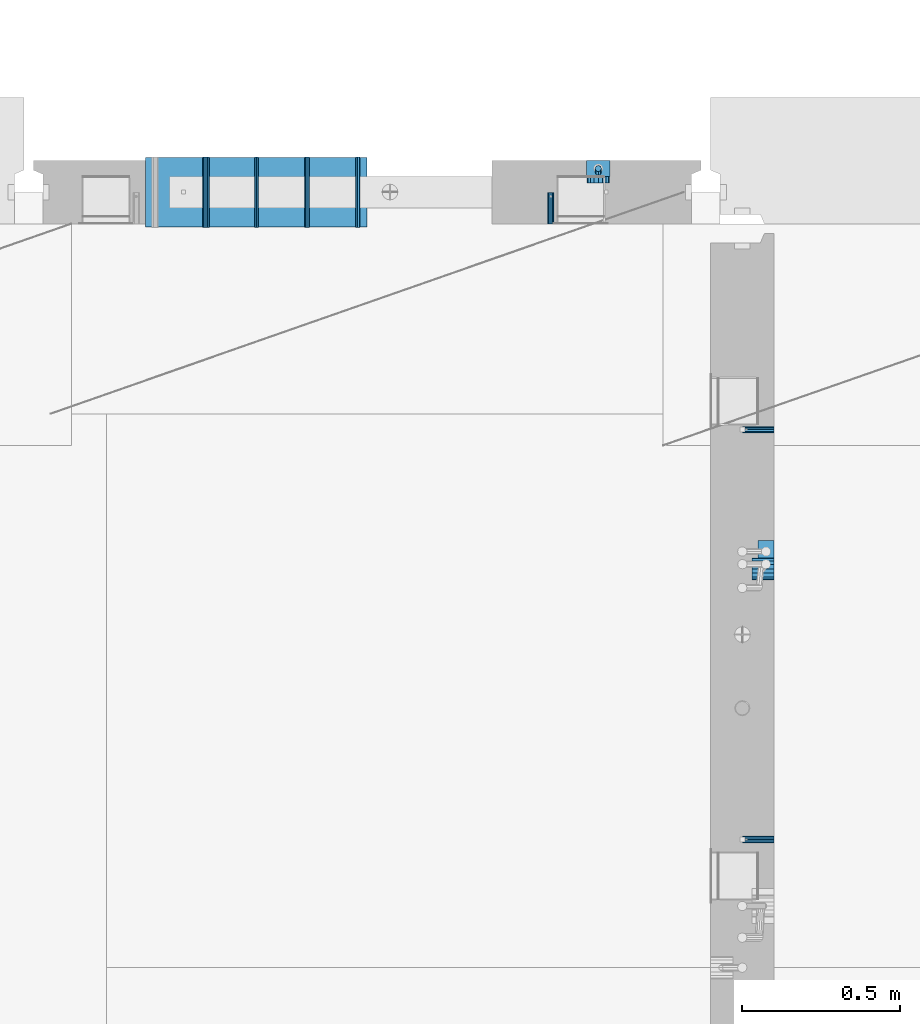
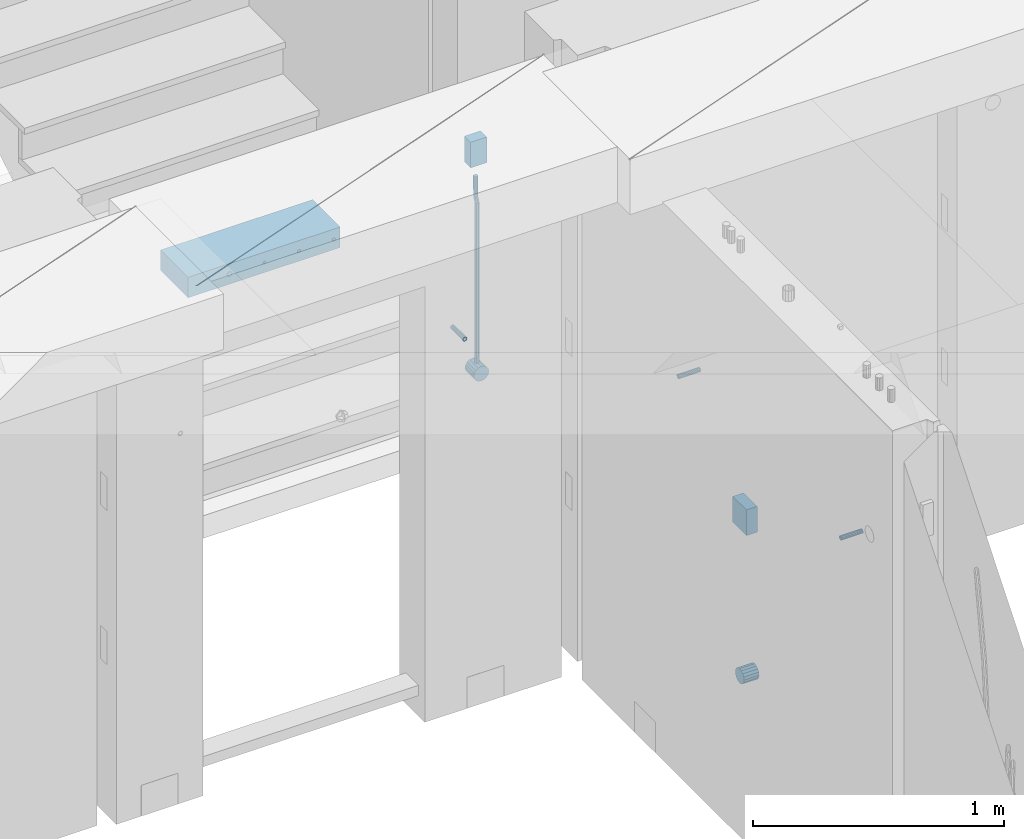
# One storey, part 144 of 341: 13 beams, 5 elements without a shape of their own.
"""IFC2X3 building model written with IfcOpenShell, lengths in millimetres."""

from ifc_helpers import new_model, si_unit, frame, origin_with_axes, place, context, subcontext, project, spatial, faceted_brep, material, type_object, element, aggregate, save


model = new_model("IFC2X3")

# Units and contexts
model_context = context("Model", 3, precision=1e-05, world=origin_with_axes())
body_context = subcontext(model_context, "Body", "Model", "MODEL_VIEW")
ifc_project = project(units=[si_unit("LENGTHUNIT", "METRE", prefix="MILLI"), si_unit("AREAUNIT", "SQUARE_METRE"), si_unit("VOLUMEUNIT", "CUBIC_METRE"), si_unit("MASSUNIT", "GRAM", prefix="KILO"), si_unit("TIMEUNIT", "SECOND"), si_unit("PLANEANGLEUNIT", "RADIAN"), si_unit("SOLIDANGLEUNIT", "STERADIAN"), si_unit("THERMODYNAMICTEMPERATUREUNIT", "DEGREE_CELSIUS"), si_unit("LUMINOUSINTENSITYUNIT", "LUMEN")], contexts=[model_context])

# Site, building, storey
site_placement = place(None, origin_with_axes())
site = spatial("IfcSite", under=ifc_project, at=site_placement, CompositionType="ELEMENT")
building_placement = place(site_placement, origin_with_axes())
building = spatial("IfcBuilding", under=site, at=building_placement, CompositionType="ELEMENT")
storey_placement = place(building_placement, origin_with_axes())
storey = spatial("IfcBuildingStorey", under=building, at=storey_placement, Name="5", CompositionType="ELEMENT", Elevation=0.0)

# Assemblies, beams
assembly_1_placement = place(storey_placement, origin_with_axes())
assembly_1 = element("IfcElementAssembly", 1, at=assembly_1_placement, inside=storey, AssemblyPlace="NOTDEFINED", PredefinedType="REINFORCEMENT_UNIT")
assembly_2_placement = place(assembly_1_placement, origin_with_axes())
assembly_2 = element("IfcElementAssembly", 2, at=assembly_2_placement, Name="Steel Assembly", AssemblyPlace="NOTDEFINED", PredefinedType="RIGID_FRAME")
ifc_material_1 = material(Name="STEEL/Steel_Undefined")
beam_type_1 = type_object("IfcBeamType", PredefinedType="NOTDEFINED")
beam_1_placement = place(assembly_2_placement, frame((21910.0, 13134.9999119588, 95555.0), z_axis=(0.0, -1.0, 0.0), x_axis=(-1.0, 3.00000001838171e-08, 0.0)))
beam_1 = element("IfcBeam", 3, at=beam_1_placement, type_object=beam_type_1, material=ifc_material_1, Name="M16", context=body_context, shape_type="Brep", body=[
    faceted_brep([(0.0, -8.49999999999272, -1.45519152283669e-11), (0.0, -7.36121593215648, 4.24999999998545), (100.000000000262, -7.36121593215648, 4.24999999998545), (100.000000000262, -8.49999999999272, -1.45519152283669e-11), (0.0, -4.24999999998545, 7.36121593216376), (100.000000000262, -4.24999999998545, 7.36121593216376), (0.0, 1.45519152283669e-11, 8.49999999998545), (100.000000000262, 1.45519152283669e-11, 8.49999999998545), (0.0, 4.25000000001455, 7.36121593216376), (100.000000000262, 4.25000000001455, 7.36121593216376), (0.0, 7.36121593217104, 4.24999999998545), (100.000000000262, 7.36121593217104, 4.24999999998545), (0.0, 8.50000000000728, 0.0), (100.000000000262, 8.50000000000728, 0.0), (0.0, 7.36121593217104, -4.25000000001455), (100.000000000262, 7.36121593217104, -4.25000000001455), (0.0, 4.25000000000728, -7.36121593219286), (100.000000000262, 4.25000000000728, -7.36121593219286), (0.0, 7.27595761418343e-12, -8.5), (100.000000000262, 7.27595761418343e-12, -8.5), (0.0, -4.24999999999272, -7.36121593217831), (100.000000000262, -4.24999999999272, -7.36121593217831), (0.0, -7.36121593215648, -4.25), (100.000000000262, -7.36121593215648, -4.25), (0.0, -10.4999999999927, -1.45519152283669e-11), (0.0, -9.09326673972828, -5.25000000001455), (100.000000000262, -9.09326673972828, -5.25000000001455), (100.000000000262, -10.4999999999927, -1.45519152283669e-11), (0.0, -5.24999999998545, -9.09326673974283), (100.000000000262, -5.24999999998545, -9.09326673974283), (0.0, 7.27595761418343e-12, -10.5), (100.000000000262, 7.27595761418343e-12, -10.5), (0.0, 5.25000000001455, -9.09326673975738), (100.000000000262, 5.25000000001455, -9.09326673975738), (0.0, 9.09326673975011, -5.25000000001455), (100.000000000262, 9.09326673975011, -5.25000000001455), (0.0, 10.5000000000073, -1.45519152283669e-11), (100.000000000262, 10.5000000000073, -1.45519152283669e-11), (0.0, 9.09326673975011, 5.25), (100.000000000262, 9.09326673975011, 5.25), (0.0, 5.25000000000728, 9.09326673972828), (100.000000000262, 5.25000000000728, 9.09326673972828), (0.0, 1.45519152283669e-11, 10.4999999999854), (100.000000000262, 1.45519152283669e-11, 10.4999999999854), (0.0, -5.24999999999272, 9.09326673972828), (100.000000000262, -5.24999999999272, 9.09326673972828), (0.0, -9.09326673972828, 5.24999999998545), (100.000000000262, -9.09326673972828, 5.24999999998545)], [[[0, 1, 2, 3]], [[1, 4, 5, 2]], [[4, 6, 7, 5]], [[6, 8, 9, 7]], [[8, 10, 11, 9]], [[10, 12, 13, 11]], [[12, 14, 15, 13]], [[14, 16, 17, 15]], [[16, 18, 19, 17]], [[18, 20, 21, 19]], [[20, 22, 23, 21]], [[22, 0, 3, 23]], [[24, 25, 26, 27]], [[25, 28, 29, 26]], [[28, 30, 31, 29]], [[30, 32, 33, 31]], [[32, 34, 35, 33]], [[34, 36, 37, 35]], [[36, 38, 39, 37]], [[38, 40, 41, 39]], [[40, 42, 43, 41]], [[42, 44, 45, 43]], [[44, 46, 47, 45]], [[46, 24, 27, 47]], [[29, 31, 33, 35, 37, 39, 41, 43, 45, 47, 27, 26], [5, 7, 9, 11, 13, 15, 17, 19, 21, 23, 3, 2]], [[46, 44, 42, 40, 38, 36, 34, 32, 30, 28, 25, 24], [22, 20, 18, 16, 14, 12, 10, 8, 6, 4, 1, 0]]]),
])
aggregate(assembly_2, [beam_1])
assembly_3_placement = place(assembly_1_placement, origin_with_axes())
assembly_3 = element("IfcElementAssembly", 4, at=assembly_3_placement, Name="Steel Assembly", AssemblyPlace="NOTDEFINED", PredefinedType="RIGID_FRAME")
beam_2_placement = place(assembly_3_placement, frame((21910.0, 14429.9999119589, 95555.0), z_axis=(0.0, 1.0, 0.0), x_axis=(-1.0, 3.00000001838171e-08, 0.0)))
beam_2 = element("IfcBeam", 5, at=beam_2_placement, type_object=beam_type_1, material=ifc_material_1, Name="M16", context=body_context, shape_type="Brep", body=[
    faceted_brep([(0.0, -8.49999999999272, -1.45519152283669e-11), (0.0, -7.36121593215648, 4.24999999998545), (100.000000000262, -7.36121593215648, 4.24999999998545), (100.000000000262, -8.49999999999272, -1.45519152283669e-11), (0.0, -4.24999999998545, 7.36121593216376), (100.000000000262, -4.24999999998545, 7.36121593216376), (0.0, 1.45519152283669e-11, 8.49999999998545), (100.000000000262, 1.45519152283669e-11, 8.49999999998545), (0.0, 4.25000000001455, 7.36121593216376), (100.000000000262, 4.25000000001455, 7.36121593216376), (0.0, 7.36121593217104, 4.24999999998545), (100.000000000262, 7.36121593217104, 4.24999999998545), (0.0, 8.50000000000728, 0.0), (100.000000000262, 8.50000000000728, 0.0), (0.0, 7.36121593217104, -4.25000000001455), (100.000000000262, 7.36121593217104, -4.25000000001455), (0.0, 4.25000000000728, -7.36121593219286), (100.000000000262, 4.25000000000728, -7.36121593219286), (0.0, 7.27595761418343e-12, -8.5), (100.000000000262, 7.27595761418343e-12, -8.5), (0.0, -4.24999999999272, -7.36121593217831), (100.000000000262, -4.24999999999272, -7.36121593217831), (0.0, -7.36121593215648, -4.25), (100.000000000262, -7.36121593215648, -4.25), (0.0, -10.4999999999927, -1.45519152283669e-11), (0.0, -9.09326673972828, -5.25000000001455), (100.000000000262, -9.09326673972828, -5.25000000001455), (100.000000000262, -10.4999999999927, -1.45519152283669e-11), (0.0, -5.24999999998545, -9.09326673974283), (100.000000000262, -5.24999999998545, -9.09326673974283), (0.0, 7.27595761418343e-12, -10.5), (100.000000000262, 7.27595761418343e-12, -10.5), (0.0, 5.25000000001455, -9.09326673975738), (100.000000000262, 5.25000000001455, -9.09326673975738), (0.0, 9.09326673975011, -5.25000000001455), (100.000000000262, 9.09326673975011, -5.25000000001455), (0.0, 10.5000000000073, -1.45519152283669e-11), (100.000000000262, 10.5000000000073, -1.45519152283669e-11), (0.0, 9.09326673975011, 5.25), (100.000000000262, 9.09326673975011, 5.25), (0.0, 5.25000000000728, 9.09326673972828), (100.000000000262, 5.25000000000728, 9.09326673972828), (0.0, 1.45519152283669e-11, 10.4999999999854), (100.000000000262, 1.45519152283669e-11, 10.4999999999854), (0.0, -5.24999999999272, 9.09326673972828), (100.000000000262, -5.24999999999272, 9.09326673972828), (0.0, -9.09326673972828, 5.24999999998545), (100.000000000262, -9.09326673972828, 5.24999999998545)], [[[0, 1, 2, 3]], [[1, 4, 5, 2]], [[4, 6, 7, 5]], [[6, 8, 9, 7]], [[8, 10, 11, 9]], [[10, 12, 13, 11]], [[12, 14, 15, 13]], [[14, 16, 17, 15]], [[16, 18, 19, 17]], [[18, 20, 21, 19]], [[20, 22, 23, 21]], [[22, 0, 3, 23]], [[24, 25, 26, 27]], [[25, 28, 29, 26]], [[28, 30, 31, 29]], [[30, 32, 33, 31]], [[32, 34, 35, 33]], [[34, 36, 37, 35]], [[36, 38, 39, 37]], [[38, 40, 41, 39]], [[40, 42, 43, 41]], [[42, 44, 45, 43]], [[44, 46, 47, 45]], [[46, 24, 27, 47]], [[29, 31, 33, 35, 37, 39, 41, 43, 45, 47, 27, 26], [5, 7, 9, 11, 13, 15, 17, 19, 21, 23, 3, 2]], [[46, 44, 42, 40, 38, 36, 34, 32, 30, 28, 25, 24], [22, 20, 18, 16, 14, 12, 10, 8, 6, 4, 1, 0]]]),
])
aggregate(assembly_3, [beam_2])

assembly_4_placement = place(storey_placement, origin_with_axes())
assembly_4 = element("IfcElementAssembly", 6, at=assembly_4_placement, inside=storey, AssemblyPlace="NOTDEFINED", PredefinedType="REINFORCEMENT_UNIT")
assembly_5_placement = place(assembly_4_placement, origin_with_axes())
assembly_5 = element("IfcElementAssembly", 7, at=assembly_5_placement, Name="Steel Assembly", AssemblyPlace="NOTDEFINED", PredefinedType="RIGID_FRAME")
beam_3_placement = place(assembly_5_placement, frame((21205.004085231, 15080.0, 95555.0), z_axis=(1.0, 0.0, 0.0), x_axis=(0.0, 1.0, 0.0)))
beam_3 = element("IfcBeam", 8, at=beam_3_placement, type_object=beam_type_1, material=ifc_material_1, Name="M16", context=body_context, shape_type="Brep", body=[
    faceted_brep([(0.0, -8.49999999999272, -1.45519152283669e-11), (0.0, -7.36121593215648, 4.24999999998545), (100.000000000262, -7.36121593215648, 4.24999999998545), (100.000000000262, -8.49999999999272, -1.45519152283669e-11), (0.0, -4.24999999998545, 7.36121593216376), (100.000000000262, -4.24999999998545, 7.36121593216376), (0.0, 1.45519152283669e-11, 8.49999999998545), (100.000000000262, 1.45519152283669e-11, 8.49999999998545), (0.0, 4.25000000001455, 7.36121593216376), (100.000000000262, 4.25000000001455, 7.36121593216376), (0.0, 7.36121593217104, 4.24999999998545), (100.000000000262, 7.36121593217104, 4.24999999998545), (0.0, 8.50000000000728, 0.0), (100.000000000262, 8.50000000000728, 0.0), (0.0, 7.36121593217104, -4.25000000001455), (100.000000000262, 7.36121593217104, -4.25000000001455), (0.0, 4.25000000000728, -7.36121593219286), (100.000000000262, 4.25000000000728, -7.36121593219286), (0.0, 7.27595761418343e-12, -8.5), (100.000000000262, 7.27595761418343e-12, -8.5), (0.0, -4.24999999999272, -7.36121593217831), (100.000000000262, -4.24999999999272, -7.36121593217831), (0.0, -7.36121593215648, -4.25), (100.000000000262, -7.36121593215648, -4.25), (0.0, -10.4999999999927, -1.45519152283669e-11), (0.0, -9.09326673972828, -5.25000000001455), (100.000000000262, -9.09326673972828, -5.25000000001455), (100.000000000262, -10.4999999999927, -1.45519152283669e-11), (0.0, -5.24999999998545, -9.09326673974283), (100.000000000262, -5.24999999998545, -9.09326673974283), (0.0, 7.27595761418343e-12, -10.5), (100.000000000262, 7.27595761418343e-12, -10.5), (0.0, 5.25000000001455, -9.09326673975738), (100.000000000262, 5.25000000001455, -9.09326673975738), (0.0, 9.09326673975011, -5.25000000001455), (100.000000000262, 9.09326673975011, -5.25000000001455), (0.0, 10.5000000000073, -1.45519152283669e-11), (100.000000000262, 10.5000000000073, -1.45519152283669e-11), (0.0, 9.09326673975011, 5.25), (100.000000000262, 9.09326673975011, 5.25), (0.0, 5.25000000000728, 9.09326673972828), (100.000000000262, 5.25000000000728, 9.09326673972828), (0.0, 1.45519152283669e-11, 10.4999999999854), (100.000000000262, 1.45519152283669e-11, 10.4999999999854), (0.0, -5.24999999999272, 9.09326673972828), (100.000000000262, -5.24999999999272, 9.09326673972828), (0.0, -9.09326673972828, 5.24999999998545), (100.000000000262, -9.09326673972828, 5.24999999998545)], [[[0, 1, 2, 3]], [[1, 4, 5, 2]], [[4, 6, 7, 5]], [[6, 8, 9, 7]], [[8, 10, 11, 9]], [[10, 12, 13, 11]], [[12, 14, 15, 13]], [[14, 16, 17, 15]], [[16, 18, 19, 17]], [[18, 20, 21, 19]], [[20, 22, 23, 21]], [[22, 0, 3, 23]], [[24, 25, 26, 27]], [[25, 28, 29, 26]], [[28, 30, 31, 29]], [[30, 32, 33, 31]], [[32, 34, 35, 33]], [[34, 36, 37, 35]], [[36, 38, 39, 37]], [[38, 40, 41, 39]], [[40, 42, 43, 41]], [[42, 44, 45, 43]], [[44, 46, 47, 45]], [[46, 24, 27, 47]], [[29, 31, 33, 35, 37, 39, 41, 43, 45, 47, 27, 26], [5, 7, 9, 11, 13, 15, 17, 19, 21, 23, 3, 2]], [[46, 44, 42, 40, 38, 36, 34, 32, 30, 28, 25, 24], [22, 20, 18, 16, 14, 12, 10, 8, 6, 4, 1, 0]]]),
])
aggregate(assembly_5, [beam_3])
ifc_material_2 = material()
beam_type_2 = type_object("IfcBeamType", Name="D20", PredefinedType="NOTDEFINED")
beam_4_placement = place(assembly_4_placement, frame((21354.9999999958, 15245.0000022759, 95290.0), z_axis=(0.00020576299992186, -0.999642804629538, -0.0267249099901004), x_axis=(-4.30000201928125e-08, -0.0267249099948059, 0.999642825806181)))
beam_4 = element("IfcBeam", 9, at=beam_4_placement, type_object=beam_type_2, material=ifc_material_2, Name="JM20", ObjectType="D20", context=body_context, shape_type="Brep", body=[
    faceted_brep([(0.0, -10.0, 0.0), (-4.19531716033816e-08, -7.07106781186667, -7.07106781187031), (60.3581158964225, -7.07106779467358, -7.07106780560207), (60.3581159005553, -9.99999998281055, 6.26459950581193e-09), (0.0, 0.0, -10.0), (60.3581158930319, 1.71930878423154e-08, -9.9999999937354), (4.196772351861e-08, 7.07106781186303, -7.07106781186667), (60.3581158923917, 7.07106782905612, -7.07106780560207), (0.0, 10.0, 0.0), (60.3581158948509, 10.0000000171895, 6.26459950581193e-09), (4.196772351861e-08, 7.07106781185939, 7.07106781185939), (60.3581158989837, 7.07106782905612, 7.07106781813127), (0.0, 0.0, 10.0), (60.3581159023597, 1.71930878423154e-08, 10.0000000062646), (-4.19531716033816e-08, -7.07106781187031, 7.07106781185939), (60.358115903, -7.07106779467722, 7.07106781813127), (60.8972477222414, -7.07106779452079, -7.07106780554386), (60.991799419251, -9.99999998403655, 6.21366780251265e-09), (60.8581158930319, 1.7334969015792e-08, -9.99999999368447), (60.8972861483926, 7.07106782920528, -7.07106780554386), (60.9917724058905, 10.0000000159635, 6.21366780251265e-09), (61.0863241029147, 7.07106782926348, 7.07106781820403), (61.1254559321096, 1.7415004549548e-08, 10.0000000063446), (61.086285676749, -7.07106779446985, 7.07106781820403), (61.4361869218264, -7.07107072394501, -7.08547838249069), (61.6251751877571, -10.0000034255863, -0.0169367769813107), (61.35793724822, -2.69946758635342e-06, -10.0133646071736), (61.4362637644808, 7.07106489957732, -7.08547940969947), (61.6252838596702, 9.99999657411536, -0.0169382296771801), (61.8142721256008, 7.07106387247404, 7.0516033758322), (61.8925217992073, -4.15200702263974e-06, 9.97948960051872), (61.814195282961, -7.07107175104829, 7.05160440304098), (775.690073058257, -7.07495307777208, -26.1837562433175), (775.879061324187, -10.0038857794134, -19.1152146378081), (775.611823384636, -0.00388505329101463, -29.1116424680004), (775.690149900896, 7.06718254575026, -26.1837572705263), (775.8791699961, 9.99611422029193, -19.1152160905003), (776.068158262031, 7.06718151865061, -12.0466744849909), (776.146407935637, -0.00388650583045091, -9.11878826030807), (776.068081419377, -7.07495410487172, -12.0466734577822), (776.844979390982, -7.07495935530824, -26.2146370302071), (778.703176670489, -10.0039011299996, -19.1907280380728), (776.111644739809, -0.00388777008629404, -29.1250070814895), (776.932750209904, 7.0671757915552, -26.2169828873994), (778.827303353013, 9.99609819560283, -19.1940455811236), (780.685500632535, 7.06715642091513, -12.1701365889894), (781.418835283708, -0.00391516431045602, -9.25976653770704), (780.597729813613, -7.07497872594467, -12.1677907318008), (777.861329320964, -7.08852484077215, -26.7638283058368), (781.188477298943, -10.0370730804789, -20.5336763496562), (776.551501535956, -0.00975865254440578, -29.362686553719), (778.026273295982, 7.05258025600779, -26.8078751783723), (781.421743305415, 9.96146953432981, -20.595968034173), (784.74889128338, 7.01292129462308, -14.3658160779887), (786.058719068402, -0.0658448936046625, -11.7669578301065), (784.583947308391, -7.12818380215685, -14.3217692054532), (795.432392943592, -7.32305037289916, -36.2584664814858), (798.759540921557, -10.2715986126059, -30.0283145252979), (794.12256515857, -0.244284184671415, -38.8573247293643), (795.597336918581, 6.81805472388078, -36.3025133540177), (798.992806928029, 9.72694400219916, -30.0906062098184), (802.319954905994, 6.77839576249244, -23.8604542536341), (803.629782691016, -0.300370425735309, -21.2615960057519), (802.15501093099, -7.3627093342875, -23.8164073811022), (799.505846831846, -7.3774198158244, -38.4595837060842), (801.367995818946, -10.3064143349802, -31.4378100447575), (798.762755292832, -0.306218002893729, -41.3646815597422), (799.574014147365, 6.7649769840682, -38.4513366830724), (801.464398961049, 9.69395502388943, -31.4261469929661), (803.32654794812, 6.76496050473361, -24.4043733316357), (804.069639487148, -0.306241308189783, -21.4992754779851), (803.258380632629, -7.37743629515535, -24.4126203546512), (804.134608044958, -7.36363999659807, -38.5831936197719), (804.332044311042, -10.2975903644801, -31.5169642204455), (804.035512197443, -0.290521008897485, -41.5054892177468), (804.092805771987, 6.77842942390271, -38.5720098863276), (804.272926969657, 9.70231601001069, -31.5011480329304), (804.470363235741, 6.76836564212863, -24.434918633604), (804.569459083272, -0.304753345568315, -21.5126230356327), (804.512165508728, -7.37370377836123, -24.4461023670447), (901.742523775247, -7.07306129268909, -41.1897886639781), (901.939960041316, -10.0070116605639, -34.1235592646481), (901.643427927731, 5.76950078539085e-05, -44.1120842619457), (901.700721502275, 7.06900812780805, -41.1786049305338), (901.880842699946, 9.99289471391967, -34.1077430771329), (902.07827896603, 7.05894434603761, -27.0415136778065), (902.177374813546, -0.0141746416556998, -24.1192180798353), (902.120081238987, -7.08312507445589, -27.0526974112508)], [[[0, 1, 2, 3]], [[1, 4, 5, 2]], [[4, 6, 7, 5]], [[6, 8, 9, 7]], [[8, 10, 11, 9]], [[10, 12, 13, 11]], [[12, 14, 15, 13]], [[14, 0, 3, 15]], [[14, 12, 10, 8, 6, 4, 1, 0]], [[3, 2, 16, 17]], [[2, 5, 18, 16]], [[5, 7, 19, 18]], [[7, 9, 20, 19]], [[9, 11, 21, 20]], [[11, 13, 22, 21]], [[13, 15, 23, 22]], [[15, 3, 17, 23]], [[17, 16, 24, 25]], [[16, 18, 26, 24]], [[18, 19, 27, 26]], [[19, 20, 28, 27]], [[20, 21, 29, 28]], [[21, 22, 30, 29]], [[22, 23, 31, 30]], [[23, 17, 25, 31]], [[25, 24, 32, 33]], [[24, 26, 34, 32]], [[26, 27, 35, 34]], [[27, 28, 36, 35]], [[28, 29, 37, 36]], [[29, 30, 38, 37]], [[30, 31, 39, 38]], [[31, 25, 33, 39]], [[33, 32, 40, 41]], [[32, 34, 42, 40]], [[34, 35, 43, 42]], [[35, 36, 44, 43]], [[36, 37, 45, 44]], [[37, 38, 46, 45]], [[38, 39, 47, 46]], [[39, 33, 41, 47]], [[41, 40, 48, 49]], [[40, 42, 50, 48]], [[42, 43, 51, 50]], [[43, 44, 52, 51]], [[44, 45, 53, 52]], [[45, 46, 54, 53]], [[46, 47, 55, 54]], [[47, 41, 49, 55]], [[49, 48, 56, 57]], [[48, 50, 58, 56]], [[50, 51, 59, 58]], [[51, 52, 60, 59]], [[52, 53, 61, 60]], [[53, 54, 62, 61]], [[54, 55, 63, 62]], [[55, 49, 57, 63]], [[57, 56, 64, 65]], [[56, 58, 66, 64]], [[58, 59, 67, 66]], [[59, 60, 68, 67]], [[60, 61, 69, 68]], [[61, 62, 70, 69]], [[62, 63, 71, 70]], [[63, 57, 65, 71]], [[65, 64, 72, 73]], [[64, 66, 74, 72]], [[66, 67, 75, 74]], [[67, 68, 76, 75]], [[68, 69, 77, 76]], [[69, 70, 78, 77]], [[70, 71, 79, 78]], [[71, 65, 73, 79]], [[73, 72, 80, 81]], [[72, 74, 82, 80]], [[74, 75, 83, 82]], [[75, 76, 84, 83]], [[76, 77, 85, 84]], [[77, 78, 86, 85]], [[78, 79, 87, 86]], [[79, 73, 81, 87]], [[82, 83, 84, 85, 86, 87, 81, 80]]]),
])

# Beam
beam_type_3 = type_object("IfcBeamType", Name="D70", PredefinedType="NOTDEFINED")
beam_5_placement = place(assembly_1_placement, frame((21910.0000022791, 13990.0, 94355.0), z_axis=(0.0, 0.0, 1.0), x_axis=(-1.0, 3.00000001838171e-08, 0.0)))
beam_5 = element("IfcBeam", 10, at=beam_5_placement, type_object=beam_type_3, material=ifc_material_2, ObjectType="D70", context=body_context, shape_type="Brep", body=[
    faceted_brep([(0.0, -35.0, 0.0), (0.0, -32.3357836378964, -13.3939201327739), (70.0, -32.3357836378964, -13.3939201327739), (70.0, -35.0, 0.0), (0.0, -24.7487373415279, -24.7487373415352), (70.0, -24.7487373415279, -24.7487373415352), (0.0, -13.3939201327776, -32.3357836379), (70.0, -13.3939201327776, -32.3357836379), (0.0, 0.0, -35.0), (70.0, 0.0, -35.0), (0.0, 13.3939201327776, -32.3357836379), (70.0, 13.3939201327776, -32.3357836379), (0.0, 24.7487373415279, -24.7487373415352), (70.0, 24.7487373415279, -24.7487373415352), (0.0, 32.3357836378964, -13.3939201327739), (70.0, 32.3357836378964, -13.3939201327739), (0.0, 35.0, 0.0), (70.0, 35.0, 0.0), (0.0, 32.3357836378964, 13.3939201327739), (70.0, 32.3357836378964, 13.3939201327739), (0.0, 24.7487373415279, 24.7487373415352), (70.0, 24.7487373415279, 24.7487373415352), (0.0, 13.3939201327776, 32.3357836379), (70.0, 13.3939201327776, 32.3357836379), (0.0, 0.0, 35.0), (70.0, 0.0, 35.0), (0.0, -13.3939201327776, 32.3357836379), (70.0, -13.3939201327776, 32.3357836379), (0.0, -24.7487373415279, 24.7487373415352), (70.0, -24.7487373415279, 24.7487373415352), (0.0, -32.3357836378964, 13.3939201327739), (70.0, -32.3357836378964, 13.3939201327739)], [[[0, 1, 2, 3]], [[1, 4, 5, 2]], [[4, 6, 7, 5]], [[6, 8, 9, 7]], [[8, 10, 11, 9]], [[10, 12, 13, 11]], [[12, 14, 15, 13]], [[14, 16, 17, 15]], [[16, 18, 19, 17]], [[18, 20, 21, 19]], [[20, 22, 23, 21]], [[22, 24, 25, 23]], [[24, 26, 27, 25]], [[26, 28, 29, 27]], [[28, 30, 31, 29]], [[30, 0, 3, 31]], [[5, 7, 9, 11, 13, 15, 17, 19, 21, 23, 25, 27, 29, 31, 3, 2]], [[30, 28, 26, 24, 22, 20, 18, 16, 14, 12, 10, 8, 6, 4, 1, 0]]]),
])

beam_6_placement = place(assembly_4_placement, frame((21354.9999999996, 15280.0000022759, 95255.0), z_axis=(0.0, 0.0, 1.0), x_axis=(0.0, -1.0, 0.0)))
beam_6 = element("IfcBeam", 11, at=beam_6_placement, type_object=beam_type_3, material=ifc_material_2, ObjectType="D70", context=body_context, shape_type="Brep", body=[
    faceted_brep([(0.0, -35.0, 0.0), (0.0, -32.3357836378964, -13.3939201327739), (70.0, -32.3357836378964, -13.3939201327739), (70.0, -35.0, 0.0), (0.0, -24.7487373415279, -24.7487373415352), (70.0, -24.7487373415279, -24.7487373415352), (0.0, -13.3939201327776, -32.3357836379), (70.0, -13.3939201327776, -32.3357836379), (0.0, 0.0, -35.0), (70.0, 0.0, -35.0), (0.0, 13.3939201327776, -32.3357836379), (70.0, 13.3939201327776, -32.3357836379), (0.0, 24.7487373415279, -24.7487373415352), (70.0, 24.7487373415279, -24.7487373415352), (0.0, 32.3357836378964, -13.3939201327739), (70.0, 32.3357836378964, -13.3939201327739), (0.0, 35.0, 0.0), (70.0, 35.0, 0.0), (0.0, 32.3357836378964, 13.3939201327739), (70.0, 32.3357836378964, 13.3939201327739), (0.0, 24.7487373415279, 24.7487373415352), (70.0, 24.7487373415279, 24.7487373415352), (0.0, 13.3939201327776, 32.3357836379), (70.0, 13.3939201327776, 32.3357836379), (0.0, 0.0, 35.0), (70.0, 0.0, 35.0), (0.0, -13.3939201327776, 32.3357836379), (70.0, -13.3939201327776, 32.3357836379), (0.0, -24.7487373415279, 24.7487373415352), (70.0, -24.7487373415279, 24.7487373415352), (0.0, -32.3357836378964, 13.3939201327739), (70.0, -32.3357836378964, 13.3939201327739)], [[[0, 1, 2, 3]], [[1, 4, 5, 2]], [[4, 6, 7, 5]], [[6, 8, 9, 7]], [[8, 10, 11, 9]], [[10, 12, 13, 11]], [[12, 14, 15, 13]], [[14, 16, 17, 15]], [[16, 18, 19, 17]], [[18, 20, 21, 19]], [[20, 22, 23, 21]], [[22, 24, 25, 23]], [[24, 26, 27, 25]], [[26, 28, 29, 27]], [[28, 30, 31, 29]], [[30, 0, 3, 31]], [[5, 7, 9, 11, 13, 15, 17, 19, 21, 23, 25, 27, 29, 31, 3, 2]], [[30, 28, 26, 24, 22, 20, 18, 16, 14, 12, 10, 8, 6, 4, 1, 0]]]),
])

ifc_material_3 = material()
beam_type_4 = type_object("IfcBeamType", Name="D12", PredefinedType="NOTDEFINED")
beam_7_placement = place(assembly_4_placement, frame((20274.9991455079, 15068.9997314798, 96260.0), z_axis=(-1.0, 3.00000001838171e-08, 0.0), x_axis=(0.0, 1.0, 0.0)))
beam_7 = element("IfcBeam", 12, at=beam_7_placement, type_object=beam_type_4, material=ifc_material_3, Name="12", ObjectType="D12", context=body_context, shape_type="Brep", body=[
    faceted_brep([(0.0, -6.0, -1.45519152283669e-11), (0.0, -4.24264068712, -4.24264068713819), (222.000077784061, -4.24264068712364, -4.24264068712), (222.000077784061, -6.0, 0.0), (3.63797880709171e-12, 0.0, -6.0000000000291), (222.000077784061, 0.0, -6.0), (0.0, 4.24264068712, -4.24264068713819), (222.000077784061, 4.24264068712364, -4.24264068712), (0.0, 6.0, -1.45519152283669e-11), (222.000077784061, 6.0, 0.0), (0.0, 4.24264068712, 4.24264068709454), (222.000077784061, 4.24264068712364, 4.24264068712), (0.0, 0.0, 5.99999999998545), (222.000077784061, 0.0, 6.0), (0.0, -4.24264068712, 4.24264068709454), (222.000077784061, -4.24264068712364, 4.24264068712)], [[[0, 1, 2, 3]], [[1, 4, 5, 2]], [[4, 6, 7, 5]], [[6, 8, 9, 7]], [[8, 10, 11, 9]], [[10, 12, 13, 11]], [[12, 14, 15, 13]], [[14, 0, 3, 15]], [[5, 7, 9, 11, 13, 15, 3, 2]], [[14, 12, 10, 8, 6, 4, 1, 0]]]),
])

beam_type_5 = type_object("IfcBeamType", Name="D15", PredefinedType="NOTDEFINED")
beam_8_placement = place(assembly_4_placement, frame((20594.99899292, 15068.9997314793, 96260.0), z_axis=(-1.0, 3.00000001838171e-08, 0.0), x_axis=(0.0, 1.0, 0.0)))
beam_8 = element("IfcBeam", 13, at=beam_8_placement, type_object=beam_type_5, material=ifc_material_3, Name="15", ObjectType="D15", context=body_context, shape_type="Brep", body=[
    faceted_brep([(0.0, -7.5, 0.0), (0.0, -5.30330085889727, -5.30330085890091), (222.000077784061, -5.30330085889727, -5.30330085890091), (222.000077784061, -7.5, 0.0), (0.0, 1.45519152283669e-11, -7.5), (222.000077784061, 0.0, -7.5), (0.0, 5.30330085889727, -5.30330085890091), (222.000077784061, 5.30330085889727, -5.30330085890091), (0.0, 7.5, 0.0), (222.000077784061, 7.5, 0.0), (0.0, 5.30330085889727, 5.30330085890091), (222.000077784061, 5.30330085889727, 5.30330085890091), (0.0, 1.45519152283669e-11, 7.5), (222.000077784061, 0.0, 7.5), (0.0, -5.30330085889727, 5.30330085890091), (222.000077784061, -5.30330085889727, 5.30330085890091)], [[[0, 1, 2, 3]], [[1, 4, 5, 2]], [[4, 6, 7, 5]], [[6, 8, 9, 7]], [[8, 10, 11, 9]], [[10, 12, 13, 11]], [[12, 14, 15, 13]], [[14, 0, 3, 15]], [[5, 7, 9, 11, 13, 15, 3, 2]], [[14, 12, 10, 8, 6, 4, 1, 0]]]),
])

beam_9_placement = place(assembly_4_placement, frame((20434.9991455079, 15068.9997314796, 96260.0), z_axis=(-1.0, 3.00000001838171e-08, 0.0), x_axis=(0.0, 1.0, 0.0)))
beam_9 = element("IfcBeam", 14, at=beam_9_placement, type_object=beam_type_5, material=ifc_material_3, Name="15", ObjectType="D15", context=body_context, shape_type="Brep", body=[
    faceted_brep([(0.0, -7.5, 0.0), (0.0, -5.30330085889727, -5.30330085890091), (222.000077784061, -5.30330085889727, -5.30330085890091), (222.000077784061, -7.5, 0.0), (0.0, 1.45519152283669e-11, -7.5), (222.000077784061, 0.0, -7.5), (0.0, 5.30330085889727, -5.30330085890091), (222.000077784061, 5.30330085889727, -5.30330085890091), (0.0, 7.5, 0.0), (222.000077784061, 7.5, 0.0), (0.0, 5.30330085889727, 5.30330085890091), (222.000077784061, 5.30330085889727, 5.30330085890091), (0.0, 1.45519152283669e-11, 7.5), (222.000077784061, 0.0, 7.5), (0.0, -5.30330085889727, 5.30330085890091), (222.000077784061, -5.30330085889727, 5.30330085890091)], [[[0, 1, 2, 3]], [[1, 4, 5, 2]], [[4, 6, 7, 5]], [[6, 8, 9, 7]], [[8, 10, 11, 9]], [[10, 12, 13, 11]], [[12, 14, 15, 13]], [[14, 0, 3, 15]], [[5, 7, 9, 11, 13, 15, 3, 2]], [[14, 12, 10, 8, 6, 4, 1, 0]]]),
])

beam_type_6 = type_object("IfcBeamType", Name="D22", PredefinedType="NOTDEFINED")
beam_10_placement = place(assembly_4_placement, frame((20114.9991455079, 15068.9997314801, 96260.0), z_axis=(-1.0, 3.00000001838171e-08, 0.0), x_axis=(0.0, 1.0, 0.0)))
beam_10 = element("IfcBeam", 15, at=beam_10_placement, type_object=beam_type_6, material=ifc_material_3, Name="22", ObjectType="D22", context=body_context, shape_type="Brep", body=[
    faceted_brep([(0.0, -11.0, 0.0), (0.0, -9.52627944163396, -5.5), (222.000077784061, -9.52627944163396, -5.5), (222.000077784061, -11.0, 0.0), (0.0, -5.5, -9.52627944163032), (222.000077784061, -5.5, -9.52627944163032), (0.0, 0.0, -11.0), (222.000077784061, 0.0, -11.0), (0.0, 5.5, -9.52627944163032), (222.000077784061, 5.5, -9.52627944163032), (0.0, 9.52627944163396, -5.5), (222.000077784061, 9.52627944163396, -5.5), (0.0, 11.0, 0.0), (222.000077784061, 11.0, 0.0), (0.0, 9.52627944163396, 5.5), (222.000077784061, 9.52627944163396, 5.5), (0.0, 5.5, 9.52627944163032), (222.000077784061, 5.5, 9.52627944163032), (0.0, 0.0, 11.0), (222.000077784061, 0.0, 11.0), (0.0, -5.5, 9.52627944163032), (222.000077784061, -5.5, 9.52627944163032), (0.0, -9.52627944163396, 5.5), (222.000077784061, -9.52627944163396, 5.5)], [[[0, 1, 2, 3]], [[1, 4, 5, 2]], [[4, 6, 7, 5]], [[6, 8, 9, 7]], [[8, 10, 11, 9]], [[10, 12, 13, 11]], [[12, 14, 15, 13]], [[14, 16, 17, 15]], [[16, 18, 19, 17]], [[18, 20, 21, 19]], [[20, 22, 23, 21]], [[22, 0, 3, 23]], [[5, 7, 9, 11, 13, 15, 17, 19, 21, 23, 3, 2]], [[22, 20, 18, 16, 14, 12, 10, 8, 6, 4, 1, 0]]]),
])

beam_type_7 = type_object("IfcBeamType", PredefinedType="NOTDEFINED")
beam_11_placement = place(assembly_4_placement, frame((20274.9991455078, 15069.9997314811, 96260.0), z_axis=(-1.0, 3.00000001838171e-08, 0.0), x_axis=(0.0, 1.0, 0.0)))
beam_11 = element("IfcBeam", 16, at=beam_11_placement, type_object=beam_type_7, material=ifc_material_3, context=body_context, shape_type="Brep", body=[
    faceted_brep([(0.0, 50.0, -350.0), (0.0, 50.0, 350.0), (220.000077784061, 50.0, 350.0), (220.000077784061, 50.0, -350.0), (0.0, -50.0, 350.0), (220.000077784061, -50.0, 350.0), (0.0, -50.0, -350.0), (220.000077784061, -50.0, -350.0)], [[[0, 1, 2, 3]], [[1, 4, 5, 2]], [[4, 6, 7, 5]], [[6, 0, 3, 7]], [[5, 7, 3, 2]], [[6, 4, 1, 0]]]),
])

beam_type_8 = type_object("IfcBeamType", Name="125X50", PredefinedType="NOTDEFINED")
beam_12_placement = place(assembly_1_placement, frame((21885.0, 13970.0, 95105.0), z_axis=(0.0, 0.0, 1.0), x_axis=(0.0, 1.0, 0.0)))
beam_12 = element("IfcBeam", 17, at=beam_12_placement, type_object=beam_type_8, material=ifc_material_2, Name="WM2", ObjectType="125X50", context=body_context, shape_type="Brep", body=[
    faceted_brep([(0.0, 25.0, -62.5), (0.0, 25.0, 62.5), (110.0, 25.0, 62.5), (110.0, 25.0, -62.5), (0.0, -25.0, 62.5), (110.0, -25.0, 62.5), (0.0, -25.0, -62.5), (110.0, -25.0, -62.5)], [[[0, 1, 2, 3]], [[1, 4, 5, 2]], [[4, 6, 7, 5]], [[6, 0, 3, 7]], [[5, 7, 3, 2]], [[0, 6, 4, 1]]]),
])

aggregate(assembly_1, [assembly_2, assembly_3, beam_12, beam_5])

beam_13_placement = place(assembly_4_placement, frame((21392.4999999996, 15254.9999999967, 96320.0), z_axis=(0.0, 0.0, 1.0), x_axis=(-1.0, 3.00000001838171e-08, 0.0)))
beam_13 = element("IfcBeam", 18, at=beam_13_placement, type_object=beam_type_8, material=ifc_material_2, Name="WM1", ObjectType="125X50", context=body_context, shape_type="Brep", body=[
    faceted_brep([(0.0, 25.0, -62.5), (0.0, 25.0, 62.5), (75.0, 25.0, 62.5), (75.0, 25.0, -62.5), (0.0, -25.0, 62.5), (75.0, -25.0, 62.5), (0.0, -25.0, -62.5), (75.0, -25.0, -62.5)], [[[0, 1, 2, 3]], [[1, 4, 5, 2]], [[4, 6, 7, 5]], [[6, 0, 3, 7]], [[5, 7, 3, 2]], [[0, 6, 4, 1]]]),
])

aggregate(assembly_4, [assembly_5, beam_13, beam_4, beam_6, beam_10, beam_7, beam_11, beam_8, beam_9])

save(model, "model.ifc")
